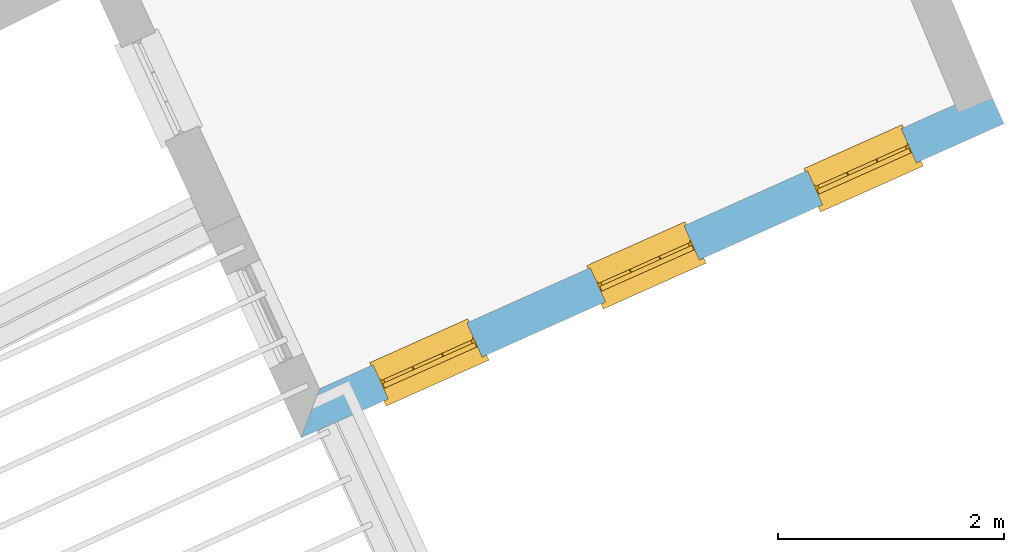
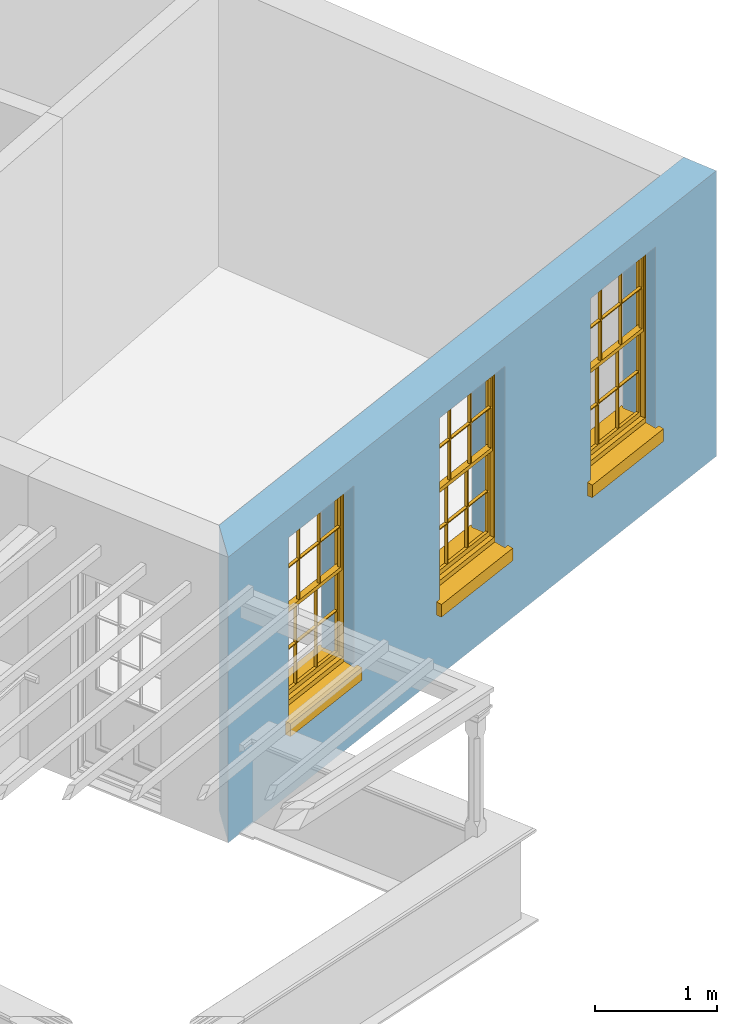
# One storey, part 4 of 9: 3 windows, 3 openings, plus 1 element that does not belong to this part.
"""IFC2X3 building model written with IfcOpenShell, lengths in metres."""

from ifc_helpers import new_model, si_unit, frame, origin, place, context, subcontext, project, spatial, polyline, outline, extrude, faceted_brep, material, layer, layer_set, layer_usage, element, fill, save


model = new_model("IFC2X3")

# Units and contexts
model_context = context("Model", 3, world=origin())
body_context = subcontext(model_context, "Body", "Model", "MODEL_VIEW")
ifc_project = project(units=[si_unit("PLANEANGLEUNIT", "RADIAN"), si_unit("MASSUNIT", "GRAM", prefix="KILO"), si_unit("FORCEUNIT", "NEWTON", prefix="KILO"), si_unit("LENGTHUNIT", "METRE")], contexts=[model_context])

# Site, building, storey
site_placement = place(None, origin())
site = spatial("IfcSite", under=ifc_project, at=site_placement, CompositionType="ELEMENT")
building_placement = place(None, origin())
building = spatial("IfcBuilding", under=site, at=building_placement, Name="Building plot-8", CompositionType="ELEMENT")
storey_placement = place(None, frame((0.0, 0.0, 3.45)))
storey = spatial("IfcBuildingStorey", under=building, at=storey_placement, Name="Floor 1", CompositionType="ELEMENT", Elevation=3.45)

# Wall, openings, windows
ifc_material = material(Name="Masonry")
ifc_layer = layer(ifc_material, 0.33, ventilated=False)
ifc_layer_set = layer_set([ifc_layer], Name="My Wall")
ifc_layer_usage = layer_usage(ifc_layer_set, "AXIS2", "NEGATIVE", 0.08)
wall_placement = place(storey_placement, origin())
wall = element("IfcWallStandardCase", 1, at=wall_placement, inside=storey, material=ifc_layer_usage, Name="exterior", context=body_context, shape_type="SweptSolid", body=[
    extrude(outline(polyline([(25.6887883842839, 9.13469885839309), (25.5254164354395, 8.70019725456561), (31.7366248764663, 11.4767371568641), (31.6019513234471, 11.778006196291), (25.6887883842839, 9.13469885839309)])), origin(), (0.0, 0.0, 1.0), 2.85),
])
opening_1_placement = place(storey_placement, frame((0.0, 0.0, 0.75)))
opening_1 = element("IfcOpeningElement", 2, at=opening_1_placement, cuts=wall, Name="Opening", ObjectType="Opening", context=body_context, shape_type="SweptSolid", body=[
    extrude(outline(polyline([(26.2953527613871, 9.04437487338484), (27.1261249610187, 9.41574739837715), (26.9914514079996, 9.71701643780401), (26.1606792083679, 9.34564391281171), (26.2953527613871, 9.04437487338484)])), origin(), (0.0, 0.0, 1.0), 1.82),
])
opening_2_placement = place(storey_placement, frame((0.0, 0.0, 0.75)))
opening_2 = element("IfcOpeningElement", 3, at=opening_2_placement, cuts=wall, Name="Opening", ObjectType="Opening", context=body_context, shape_type="SweptSolid", body=[
    extrude(outline(polyline([(28.2144135191812, 9.90223511419651), (29.0451857188129, 10.2736076391888), (28.9105121657937, 10.5748766786157), (28.0797399661621, 10.2035041536234), (28.2144135191812, 9.90223511419651)])), origin(), (0.0, 0.0, 1.0), 1.82),
])
opening_3_placement = place(storey_placement, frame((0.0, 0.0, 0.75)))
opening_3 = element("IfcOpeningElement", 4, at=opening_3_placement, cuts=wall, Name="Opening", ObjectType="Opening", context=body_context, shape_type="SweptSolid", body=[
    extrude(outline(polyline([(30.1334742769754, 10.7600953550082), (30.9642464766071, 11.1314678800005), (30.8295729235879, 11.4327369194274), (29.9988007239562, 11.0613643944351), (30.1334742769754, 10.7600953550082)])), origin(), (0.0, 0.0, 1.0), 1.82),
])
window_1_placement = place(storey_placement, frame((26.1933273424331, 9.27260899416277, 0.75), z_axis=(0.0, 0.0, 1.0), x_axis=(0.830772199631671, 0.371372524992305, 0.0)))
window_1 = element("IfcWindow", 5, at=window_1_placement, inside=storey, Name="living outside window", OverallHeight=1.82, OverallWidth=0.91, context=body_context, shape_type="Brep", held_by="IfcProductRepresentation", body=[
    faceted_brep([(0.033125, -0.105, 0.975209), (0.01, -0.105, 0.975209), (0.033125, -0.105, 1.376042), (0.876875, -0.105, 0.975209), (0.876875, -0.105, 1.376042), (0.9, -0.105, 0.975209), (0.876875, -0.105, 1.386042), (0.876875, -0.105, 1.786875), (0.9, -0.105, 1.81), (0.033125, -0.105, 1.786875), (0.033125, -0.105, 1.386042), (0.01, -0.105, 1.81), (0.876875, -0.135, 1.376042), (0.876875, -0.135, 0.975209), (0.9, -0.135, 0.937083), (0.033125, -0.135, 1.786875), (0.01, -0.135, 1.81), (0.033125, -0.135, 1.386042), (0.01, -0.135, 0.937083), (0.033125, -0.135, 0.975209), (0.033125, -0.135, 1.376042), (0.876875, -0.135, 1.786875), (0.876875, -0.135, 1.386042), (0.9, -0.135, 1.81), (0.033125, -0.105, 0.937083), (0.01, -0.105, 0.937083), (0.033125, -0.105, 0.53625), (0.876875, -0.105, 0.937083), (0.876875, -0.105, 0.53625), (0.9, -0.105, 0.937083), (0.876875, -0.105, 0.52625), (0.876875, -0.105, 0.125417), (0.9, -0.105, 0.077167), (0.033125, -0.105, 0.125417), (0.033125, -0.105, 0.52625), (0.01, -0.105, 0.077167), (-0.0425, -0.25, 0.01), (-0.0425, -0.3, 0.001667), (0.0, -0.25, 0.01), (0.9525, -0.25, 0.01), (0.91, -0.25, 0.01), (0.9525, -0.3, 0.001667), (-0.02, 0.08, 0.077167), (0.0, 0.08, 0.077167), (-0.02, 0.11, 0.077167), (0.0, -0.06, 0.077167), (0.01, -0.06, 0.077167), (0.91, -0.06, 0.077167), (0.91, 0.08, 0.077167), (0.9, -0.06, 0.077167), (0.93, 0.08, 0.077167), (0.93, 0.11, 0.077167), (0.01, -0.075, 0.975209), (0.9, -0.075, 0.975209), (0.876875, -0.075, 0.125417), (0.876875, -0.075, 0.52625), (0.9, -0.075, 0.077167), (0.876875, -0.075, 0.53625), (0.876875, -0.075, 0.937083), (0.033125, -0.075, 0.125417), (0.01, -0.075, 0.077167), (0.033125, -0.075, 0.52625), (0.033125, -0.075, 0.937083), (0.033125, -0.075, 0.53625), (-0.02, 0.08, 0.052167), (-0.02, 0.11, 0.052167), (0.93, 0.11, 0.052167), (0.93, 0.08, 0.052167), (0.91, 0.08, 0.052167), (0.0, 0.08, 0.052167), (0.91, -0.15, 0.026667), (0.0, -0.15, 0.026667), (-0.0425, -0.3, -0.123333), (0.9525, -0.3, -0.123333), (-0.0425, -0.25, -0.123333), (0.9525, -0.25, -0.123333), (0.01, -0.06, 1.81), (0.9, -0.06, 1.81), (0.0, -0.06, 1.82), (0.91, -0.06, 1.82), (0.01, -0.15, 0.077167), (0.9, -0.15, 0.077167), (0.592292, -0.105, 0.125417), (0.592292, -0.075, 0.125417), (0.317708, -0.075, 0.125417), (0.317708, -0.105, 0.125417), (0.592292, -0.105, 0.53625), (0.317708, -0.105, 0.53625), (0.317708, -0.105, 0.52625), (0.592292, -0.105, 0.52625), (0.592292, -0.075, 0.53625), (0.317708, -0.075, 0.53625), (0.592292, -0.135, 1.386042), (0.592292, -0.105, 1.386042), (0.317708, -0.105, 1.386042), (0.317708, -0.135, 1.386042), (0.317708, -0.135, 1.376042), (0.592292, -0.135, 1.376042), (0.317708, -0.105, 1.376042), (0.592292, -0.105, 1.376042), (0.602292, -0.135, 1.376042), (0.592292, -0.135, 0.975209), (0.602292, -0.135, 0.975209), (0.602292, -0.105, 0.975209), (0.592292, -0.105, 0.975209), (0.602292, -0.105, 1.376042), (0.602292, -0.075, 0.53625), (0.602292, -0.105, 0.53625), (0.317708, -0.075, 0.52625), (0.307708, -0.075, 0.125417), (0.307708, -0.075, 0.52625), (0.602292, -0.075, 0.52625), (0.602292, -0.075, 0.125417), (0.592292, -0.075, 0.52625), (0.307708, -0.075, 0.53625), (0.317708, -0.075, 0.937083), (0.307708, -0.075, 0.937083), (0.602292, -0.075, 0.937083), (0.592292, -0.075, 0.937083), (0.307708, -0.105, 0.52625), (0.307708, -0.105, 0.125417), (0.307708, -0.105, 0.53625), (0.307708, -0.105, 0.937083), (0.592292, -0.105, 0.937083), (0.317708, -0.105, 0.937083), (0.602292, -0.105, 0.937083), (0.602292, -0.105, 0.52625), (0.602292, -0.105, 0.125417), (0.307708, -0.135, 1.386042), (0.307708, -0.135, 1.376042), (0.307708, -0.135, 0.975209), (0.317708, -0.135, 0.975209), (0.317708, -0.135, 1.786875), (0.307708, -0.135, 1.786875), (0.602292, -0.135, 1.786875), (0.592292, -0.135, 1.786875), (0.602292, -0.135, 1.386042), (0.602292, -0.105, 1.386042), (0.307708, -0.105, 1.386042), (0.307708, -0.105, 1.786875), (0.317708, -0.105, 1.786875), (0.592292, -0.105, 1.786875), (0.602292, -0.105, 1.786875), (0.307708, -0.105, 1.376042), (0.317708, -0.105, 0.975209), (0.307708, -0.105, 0.975209), (0.91, -0.15, 1.82), (0.9, -0.15, 1.81), (0.01, -0.15, 1.81), (0.0, -0.15, 1.82), (0.91, -0.25, 0.0), (0.0, -0.25, 0.0), (0.91, 0.08, 0.0), (0.0, 0.08, 0.0)], [[[0, 1, 2]], [[3, 4, 5]], [[6, 7, 8]], [[9, 10, 11]], [[12, 13, 14]], [[15, 16, 17]], [[18, 19, 20]], [[21, 22, 23]], [[24, 25, 26]], [[27, 28, 29]], [[30, 31, 32]], [[33, 34, 35]], [[14, 27, 29]], [[25, 24, 18]], [[36, 37, 38]], [[39, 40, 41]], [[42, 43, 44]], [[45, 46, 43]], [[47, 48, 49]], [[50, 51, 48]], [[1, 0, 52]], [[5, 53, 3]], [[54, 55, 56]], [[57, 58, 53]], [[59, 60, 61]], [[62, 63, 52]], [[48, 43, 46, 49]], [[51, 44, 43, 48]], [[64, 42, 44, 65]], [[65, 44, 51, 66]], [[66, 51, 50, 67]], [[65, 66, 68, 69]], [[60, 56, 49, 46]], [[70, 71, 38, 40]], [[37, 41, 40, 38]], [[37, 72, 73, 41]], [[74, 75, 73, 72]], [[8, 11, 76, 77]], [[76, 78, 79, 77]], [[32, 35, 80, 81]], [[81, 80, 71, 70]], [[82, 83, 84, 85]], [[86, 87, 88, 89]], [[86, 90, 91, 87]], [[92, 93, 94, 95]], [[92, 95, 96, 97]], [[96, 98, 99, 97]], [[100, 97, 101, 102]], [[103, 104, 99, 105]], [[97, 99, 104, 101]], [[102, 103, 105, 100]], [[28, 57, 106, 107]], [[108, 84, 109, 110]], [[111, 112, 83, 113]], [[114, 110, 61, 63]], [[90, 113, 108, 91]], [[115, 91, 114, 116]], [[117, 106, 90, 118]], [[111, 106, 57, 55]], [[119, 110, 109, 120]], [[34, 61, 110, 119]], [[89, 113, 83, 82]], [[88, 108, 113, 89]], [[85, 84, 108, 88]], [[121, 114, 63, 26]], [[122, 116, 114, 121]], [[123, 118, 90, 86]], [[87, 91, 115, 124]], [[107, 106, 117, 125]], [[126, 111, 55, 30]], [[127, 112, 111, 126]], [[126, 30, 28, 107]], [[88, 119, 120, 85]], [[126, 89, 82, 127]], [[125, 123, 86, 107]], [[121, 26, 34, 119]], [[124, 122, 121, 87]], [[128, 17, 20, 129]], [[96, 129, 130, 131]], [[132, 133, 128, 95]], [[134, 135, 92, 136]], [[100, 12, 22, 136]], [[137, 6, 4, 105]], [[94, 138, 139, 140]], [[137, 93, 141, 142]], [[99, 98, 94, 93]], [[143, 2, 10, 138]], [[144, 145, 143, 98]], [[129, 143, 145, 130]], [[20, 2, 143, 129]], [[131, 144, 98, 96]], [[128, 138, 10, 17]], [[133, 139, 138, 128]], [[135, 141, 93, 92]], [[95, 94, 140, 132]], [[22, 6, 137, 136]], [[136, 137, 142, 134]], [[100, 105, 4, 12]], [[107, 86, 89, 126]], [[106, 111, 113, 90]], [[91, 108, 110, 114]], [[87, 121, 119, 88]], [[97, 100, 136, 92]], [[129, 96, 95, 128]], [[98, 143, 138, 94]], [[105, 99, 93, 137]], [[131, 101, 104, 144]], [[124, 115, 118, 123]], [[132, 140, 141, 135]], [[120, 109, 59, 33]], [[15, 9, 139, 133]], [[134, 142, 7, 21]], [[31, 54, 112, 127]], [[36, 74, 72, 37]], [[39, 41, 73, 75]], [[18, 14, 101, 131]], [[23, 16, 132, 135]], [[83, 56, 60, 84]], [[52, 53, 118, 115]], [[53, 52, 144, 104]], [[11, 8, 141, 140]], [[14, 18, 124, 123]], [[2, 1, 11, 10]], [[8, 5, 4, 6]], [[57, 53, 56, 55]], [[60, 52, 63, 61]], [[26, 25, 35, 34]], [[32, 29, 28, 30]], [[14, 23, 22, 12]], [[18, 20, 17, 16]], [[19, 0, 2, 20]], [[17, 10, 9, 15]], [[12, 4, 3, 13]], [[21, 7, 6, 22]], [[27, 58, 57, 28]], [[30, 55, 54, 31]], [[33, 59, 61, 34]], [[26, 63, 62, 24]], [[5, 8, 77, 53]], [[76, 11, 1, 52]], [[46, 45, 78, 76]], [[49, 77, 79, 47]], [[70, 146, 147, 81]], [[71, 80, 148, 149]], [[19, 130, 145, 0]], [[102, 13, 3, 103]], [[116, 122, 24, 62]], [[29, 32, 81, 14]], [[80, 35, 25, 18]], [[60, 46, 76, 52]], [[77, 49, 56, 53]], [[23, 14, 81, 147]], [[16, 148, 80, 18]], [[35, 85, 120]], [[120, 33, 35]], [[127, 82, 32]], [[32, 31, 127]], [[32, 82, 85, 35]], [[102, 101, 14]], [[14, 13, 102]], [[18, 131, 130]], [[130, 19, 18]], [[134, 21, 23]], [[23, 135, 134]], [[16, 15, 133]], [[133, 132, 16]], [[11, 140, 139]], [[139, 9, 11]], [[142, 141, 8]], [[8, 7, 142]], [[23, 147, 148, 16]], [[146, 149, 148, 147]], [[52, 115, 116]], [[116, 62, 52]], [[118, 53, 117]], [[58, 117, 53]], [[27, 125, 117, 58]], [[56, 83, 112]], [[112, 54, 56]], [[109, 84, 60]], [[60, 59, 109]], [[125, 27, 14]], [[14, 123, 125]], [[122, 124, 18]], [[18, 24, 122]], [[145, 144, 52]], [[52, 0, 145]], [[103, 3, 53]], [[53, 104, 103]], [[79, 78, 149, 146]], [[78, 45, 71, 149]], [[146, 70, 47, 79]], [[150, 75, 74, 151]], [[68, 66, 67]], [[48, 68, 67, 50]], [[69, 64, 65]], [[42, 64, 69, 43]], [[69, 68, 152, 153]], [[70, 68, 48, 47]], [[150, 152, 68, 70]], [[43, 69, 71, 45]], [[69, 153, 151, 71]], [[152, 150, 151, 153]], [[38, 151, 74, 36]], [[71, 151, 38]], [[39, 75, 150, 40]], [[40, 150, 70]]]),
])
fill(opening_1, window_1)
window_2_placement = place(storey_placement, frame((28.1123881002273, 10.1304692349744, 0.75), z_axis=(0.0, 0.0, 1.0), x_axis=(0.830772199631671, 0.371372524992303, 0.0)))
window_2 = element("IfcWindow", 6, at=window_2_placement, inside=storey, Name="living outside window", OverallHeight=1.82, OverallWidth=0.91, context=body_context, shape_type="Brep", held_by="IfcProductRepresentation", body=[
    faceted_brep([(0.033125, -0.105, 0.975209), (0.01, -0.105, 0.975209), (0.033125, -0.105, 1.376042), (0.876875, -0.105, 0.975209), (0.876875, -0.105, 1.376042), (0.9, -0.105, 0.975209), (0.876875, -0.105, 1.386042), (0.876875, -0.105, 1.786875), (0.9, -0.105, 1.81), (0.033125, -0.105, 1.786875), (0.033125, -0.105, 1.386042), (0.01, -0.105, 1.81), (0.876875, -0.135, 1.376042), (0.876875, -0.135, 0.975209), (0.9, -0.135, 0.937083), (0.033125, -0.135, 1.786875), (0.01, -0.135, 1.81), (0.033125, -0.135, 1.386042), (0.01, -0.135, 0.937083), (0.033125, -0.135, 0.975209), (0.033125, -0.135, 1.376042), (0.876875, -0.135, 1.786875), (0.876875, -0.135, 1.386042), (0.9, -0.135, 1.81), (0.033125, -0.105, 0.937083), (0.01, -0.105, 0.937083), (0.033125, -0.105, 0.53625), (0.876875, -0.105, 0.937083), (0.876875, -0.105, 0.53625), (0.9, -0.105, 0.937083), (0.876875, -0.105, 0.52625), (0.876875, -0.105, 0.125417), (0.9, -0.105, 0.077167), (0.033125, -0.105, 0.125417), (0.033125, -0.105, 0.52625), (0.01, -0.105, 0.077167), (-0.0425, -0.25, 0.01), (-0.0425, -0.3, 0.001667), (0.0, -0.25, 0.01), (0.9525, -0.25, 0.01), (0.91, -0.25, 0.01), (0.9525, -0.3, 0.001667), (-0.02, 0.08, 0.077167), (0.0, 0.08, 0.077167), (-0.02, 0.11, 0.077167), (0.0, -0.06, 0.077167), (0.01, -0.06, 0.077167), (0.91, -0.06, 0.077167), (0.91, 0.08, 0.077167), (0.9, -0.06, 0.077167), (0.93, 0.08, 0.077167), (0.93, 0.11, 0.077167), (0.01, -0.075, 0.975209), (0.9, -0.075, 0.975209), (0.876875, -0.075, 0.125417), (0.876875, -0.075, 0.52625), (0.9, -0.075, 0.077167), (0.876875, -0.075, 0.53625), (0.876875, -0.075, 0.937083), (0.033125, -0.075, 0.125417), (0.01, -0.075, 0.077167), (0.033125, -0.075, 0.52625), (0.033125, -0.075, 0.937083), (0.033125, -0.075, 0.53625), (-0.02, 0.08, 0.052167), (-0.02, 0.11, 0.052167), (0.93, 0.11, 0.052167), (0.93, 0.08, 0.052167), (0.91, 0.08, 0.052167), (0.0, 0.08, 0.052167), (0.91, -0.15, 0.026667), (0.0, -0.15, 0.026667), (-0.0425, -0.3, -0.123333), (0.9525, -0.3, -0.123333), (-0.0425, -0.25, -0.123333), (0.9525, -0.25, -0.123333), (0.01, -0.06, 1.81), (0.9, -0.06, 1.81), (0.0, -0.06, 1.82), (0.91, -0.06, 1.82), (0.01, -0.15, 0.077167), (0.9, -0.15, 0.077167), (0.592292, -0.105, 0.125417), (0.592292, -0.075, 0.125417), (0.317708, -0.075, 0.125417), (0.317708, -0.105, 0.125417), (0.592292, -0.105, 0.53625), (0.317708, -0.105, 0.53625), (0.317708, -0.105, 0.52625), (0.592292, -0.105, 0.52625), (0.592292, -0.075, 0.53625), (0.317708, -0.075, 0.53625), (0.592292, -0.135, 1.386042), (0.592292, -0.105, 1.386042), (0.317708, -0.105, 1.386042), (0.317708, -0.135, 1.386042), (0.317708, -0.135, 1.376042), (0.592292, -0.135, 1.376042), (0.317708, -0.105, 1.376042), (0.592292, -0.105, 1.376042), (0.602292, -0.135, 1.376042), (0.592292, -0.135, 0.975209), (0.602292, -0.135, 0.975209), (0.602292, -0.105, 0.975209), (0.592292, -0.105, 0.975209), (0.602292, -0.105, 1.376042), (0.602292, -0.075, 0.53625), (0.602292, -0.105, 0.53625), (0.317708, -0.075, 0.52625), (0.307708, -0.075, 0.125417), (0.307708, -0.075, 0.52625), (0.602292, -0.075, 0.52625), (0.602292, -0.075, 0.125417), (0.592292, -0.075, 0.52625), (0.307708, -0.075, 0.53625), (0.317708, -0.075, 0.937083), (0.307708, -0.075, 0.937083), (0.602292, -0.075, 0.937083), (0.592292, -0.075, 0.937083), (0.307708, -0.105, 0.52625), (0.307708, -0.105, 0.125417), (0.307708, -0.105, 0.53625), (0.307708, -0.105, 0.937083), (0.592292, -0.105, 0.937083), (0.317708, -0.105, 0.937083), (0.602292, -0.105, 0.937083), (0.602292, -0.105, 0.52625), (0.602292, -0.105, 0.125417), (0.307708, -0.135, 1.386042), (0.307708, -0.135, 1.376042), (0.307708, -0.135, 0.975209), (0.317708, -0.135, 0.975209), (0.317708, -0.135, 1.786875), (0.307708, -0.135, 1.786875), (0.602292, -0.135, 1.786875), (0.592292, -0.135, 1.786875), (0.602292, -0.135, 1.386042), (0.602292, -0.105, 1.386042), (0.307708, -0.105, 1.386042), (0.307708, -0.105, 1.786875), (0.317708, -0.105, 1.786875), (0.592292, -0.105, 1.786875), (0.602292, -0.105, 1.786875), (0.307708, -0.105, 1.376042), (0.317708, -0.105, 0.975209), (0.307708, -0.105, 0.975209), (0.91, -0.15, 1.82), (0.9, -0.15, 1.81), (0.01, -0.15, 1.81), (0.0, -0.15, 1.82), (0.91, -0.25, 0.0), (0.0, -0.25, 0.0), (0.91, 0.08, 0.0), (0.0, 0.08, 0.0)], [[[0, 1, 2]], [[3, 4, 5]], [[6, 7, 8]], [[9, 10, 11]], [[12, 13, 14]], [[15, 16, 17]], [[18, 19, 20]], [[21, 22, 23]], [[24, 25, 26]], [[27, 28, 29]], [[30, 31, 32]], [[33, 34, 35]], [[14, 27, 29]], [[25, 24, 18]], [[36, 37, 38]], [[39, 40, 41]], [[42, 43, 44]], [[45, 46, 43]], [[47, 48, 49]], [[50, 51, 48]], [[1, 0, 52]], [[5, 53, 3]], [[54, 55, 56]], [[57, 58, 53]], [[59, 60, 61]], [[62, 63, 52]], [[48, 43, 46, 49]], [[51, 44, 43, 48]], [[64, 42, 44, 65]], [[65, 44, 51, 66]], [[66, 51, 50, 67]], [[65, 66, 68, 69]], [[60, 56, 49, 46]], [[70, 71, 38, 40]], [[37, 41, 40, 38]], [[37, 72, 73, 41]], [[74, 75, 73, 72]], [[8, 11, 76, 77]], [[76, 78, 79, 77]], [[32, 35, 80, 81]], [[81, 80, 71, 70]], [[82, 83, 84, 85]], [[86, 87, 88, 89]], [[86, 90, 91, 87]], [[92, 93, 94, 95]], [[92, 95, 96, 97]], [[96, 98, 99, 97]], [[100, 97, 101, 102]], [[103, 104, 99, 105]], [[97, 99, 104, 101]], [[102, 103, 105, 100]], [[28, 57, 106, 107]], [[108, 84, 109, 110]], [[111, 112, 83, 113]], [[114, 110, 61, 63]], [[90, 113, 108, 91]], [[115, 91, 114, 116]], [[117, 106, 90, 118]], [[111, 106, 57, 55]], [[119, 110, 109, 120]], [[34, 61, 110, 119]], [[89, 113, 83, 82]], [[88, 108, 113, 89]], [[85, 84, 108, 88]], [[121, 114, 63, 26]], [[122, 116, 114, 121]], [[123, 118, 90, 86]], [[87, 91, 115, 124]], [[107, 106, 117, 125]], [[126, 111, 55, 30]], [[127, 112, 111, 126]], [[126, 30, 28, 107]], [[88, 119, 120, 85]], [[126, 89, 82, 127]], [[125, 123, 86, 107]], [[121, 26, 34, 119]], [[124, 122, 121, 87]], [[128, 17, 20, 129]], [[96, 129, 130, 131]], [[132, 133, 128, 95]], [[134, 135, 92, 136]], [[100, 12, 22, 136]], [[137, 6, 4, 105]], [[94, 138, 139, 140]], [[137, 93, 141, 142]], [[99, 98, 94, 93]], [[143, 2, 10, 138]], [[144, 145, 143, 98]], [[129, 143, 145, 130]], [[20, 2, 143, 129]], [[131, 144, 98, 96]], [[128, 138, 10, 17]], [[133, 139, 138, 128]], [[135, 141, 93, 92]], [[95, 94, 140, 132]], [[22, 6, 137, 136]], [[136, 137, 142, 134]], [[100, 105, 4, 12]], [[107, 86, 89, 126]], [[106, 111, 113, 90]], [[91, 108, 110, 114]], [[87, 121, 119, 88]], [[97, 100, 136, 92]], [[129, 96, 95, 128]], [[98, 143, 138, 94]], [[105, 99, 93, 137]], [[131, 101, 104, 144]], [[124, 115, 118, 123]], [[132, 140, 141, 135]], [[120, 109, 59, 33]], [[15, 9, 139, 133]], [[134, 142, 7, 21]], [[31, 54, 112, 127]], [[36, 74, 72, 37]], [[39, 41, 73, 75]], [[18, 14, 101, 131]], [[23, 16, 132, 135]], [[83, 56, 60, 84]], [[52, 53, 118, 115]], [[53, 52, 144, 104]], [[11, 8, 141, 140]], [[14, 18, 124, 123]], [[2, 1, 11, 10]], [[8, 5, 4, 6]], [[57, 53, 56, 55]], [[60, 52, 63, 61]], [[26, 25, 35, 34]], [[32, 29, 28, 30]], [[14, 23, 22, 12]], [[18, 20, 17, 16]], [[19, 0, 2, 20]], [[17, 10, 9, 15]], [[12, 4, 3, 13]], [[21, 7, 6, 22]], [[27, 58, 57, 28]], [[30, 55, 54, 31]], [[33, 59, 61, 34]], [[26, 63, 62, 24]], [[5, 8, 77, 53]], [[76, 11, 1, 52]], [[46, 45, 78, 76]], [[49, 77, 79, 47]], [[70, 146, 147, 81]], [[71, 80, 148, 149]], [[19, 130, 145, 0]], [[102, 13, 3, 103]], [[116, 122, 24, 62]], [[29, 32, 81, 14]], [[80, 35, 25, 18]], [[60, 46, 76, 52]], [[77, 49, 56, 53]], [[23, 14, 81, 147]], [[16, 148, 80, 18]], [[35, 85, 120]], [[120, 33, 35]], [[127, 82, 32]], [[32, 31, 127]], [[32, 82, 85, 35]], [[102, 101, 14]], [[14, 13, 102]], [[18, 131, 130]], [[130, 19, 18]], [[134, 21, 23]], [[23, 135, 134]], [[16, 15, 133]], [[133, 132, 16]], [[11, 140, 139]], [[139, 9, 11]], [[142, 141, 8]], [[8, 7, 142]], [[23, 147, 148, 16]], [[146, 149, 148, 147]], [[52, 115, 116]], [[116, 62, 52]], [[118, 53, 117]], [[58, 117, 53]], [[27, 125, 117, 58]], [[56, 83, 112]], [[112, 54, 56]], [[109, 84, 60]], [[60, 59, 109]], [[125, 27, 14]], [[14, 123, 125]], [[122, 124, 18]], [[18, 24, 122]], [[145, 144, 52]], [[52, 0, 145]], [[103, 3, 53]], [[53, 104, 103]], [[79, 78, 149, 146]], [[78, 45, 71, 149]], [[146, 70, 47, 79]], [[150, 75, 74, 151]], [[68, 66, 67]], [[48, 68, 67, 50]], [[69, 64, 65]], [[42, 64, 69, 43]], [[69, 68, 152, 153]], [[70, 68, 48, 47]], [[150, 152, 68, 70]], [[43, 69, 71, 45]], [[69, 153, 151, 71]], [[152, 150, 151, 153]], [[38, 151, 74, 36]], [[71, 151, 38]], [[39, 75, 150, 40]], [[40, 150, 70]]]),
])
fill(opening_2, window_2)
window_3_placement = place(storey_placement, frame((30.0314488580215, 10.9883294757861, 0.75), z_axis=(0.0, 0.0, 1.0), x_axis=(0.830772199631671, 0.371372524992303, 0.0)))
window_3 = element("IfcWindow", 7, at=window_3_placement, inside=storey, Name="living outside window", OverallHeight=1.82, OverallWidth=0.91, context=body_context, shape_type="Brep", held_by="IfcProductRepresentation", body=[
    faceted_brep([(0.033125, -0.105, 0.975209), (0.01, -0.105, 0.975209), (0.033125, -0.105, 1.376042), (0.876875, -0.105, 0.975209), (0.876875, -0.105, 1.376042), (0.9, -0.105, 0.975209), (0.876875, -0.105, 1.386042), (0.876875, -0.105, 1.786875), (0.9, -0.105, 1.81), (0.033125, -0.105, 1.786875), (0.033125, -0.105, 1.386042), (0.01, -0.105, 1.81), (0.876875, -0.135, 1.376042), (0.876875, -0.135, 0.975209), (0.9, -0.135, 0.937083), (0.033125, -0.135, 1.786875), (0.01, -0.135, 1.81), (0.033125, -0.135, 1.386042), (0.01, -0.135, 0.937083), (0.033125, -0.135, 0.975209), (0.033125, -0.135, 1.376042), (0.876875, -0.135, 1.786875), (0.876875, -0.135, 1.386042), (0.9, -0.135, 1.81), (0.033125, -0.105, 0.937083), (0.01, -0.105, 0.937083), (0.033125, -0.105, 0.53625), (0.876875, -0.105, 0.937083), (0.876875, -0.105, 0.53625), (0.9, -0.105, 0.937083), (0.876875, -0.105, 0.52625), (0.876875, -0.105, 0.125417), (0.9, -0.105, 0.077167), (0.033125, -0.105, 0.125417), (0.033125, -0.105, 0.52625), (0.01, -0.105, 0.077167), (-0.0425, -0.25, 0.01), (-0.0425, -0.3, 0.001667), (0.0, -0.25, 0.01), (0.9525, -0.25, 0.01), (0.91, -0.25, 0.01), (0.9525, -0.3, 0.001667), (-0.02, 0.08, 0.077167), (0.0, 0.08, 0.077167), (-0.02, 0.11, 0.077167), (0.0, -0.06, 0.077167), (0.01, -0.06, 0.077167), (0.91, -0.06, 0.077167), (0.91, 0.08, 0.077167), (0.9, -0.06, 0.077167), (0.93, 0.08, 0.077167), (0.93, 0.11, 0.077167), (0.01, -0.075, 0.975209), (0.9, -0.075, 0.975209), (0.876875, -0.075, 0.125417), (0.876875, -0.075, 0.52625), (0.9, -0.075, 0.077167), (0.876875, -0.075, 0.53625), (0.876875, -0.075, 0.937083), (0.033125, -0.075, 0.125417), (0.01, -0.075, 0.077167), (0.033125, -0.075, 0.52625), (0.033125, -0.075, 0.937083), (0.033125, -0.075, 0.53625), (-0.02, 0.08, 0.052167), (-0.02, 0.11, 0.052167), (0.93, 0.11, 0.052167), (0.93, 0.08, 0.052167), (0.91, 0.08, 0.052167), (0.0, 0.08, 0.052167), (0.91, -0.15, 0.026667), (0.0, -0.15, 0.026667), (-0.0425, -0.3, -0.123333), (0.9525, -0.3, -0.123333), (-0.0425, -0.25, -0.123333), (0.9525, -0.25, -0.123333), (0.01, -0.06, 1.81), (0.9, -0.06, 1.81), (0.0, -0.06, 1.82), (0.91, -0.06, 1.82), (0.01, -0.15, 0.077167), (0.9, -0.15, 0.077167), (0.592292, -0.105, 0.125417), (0.592292, -0.075, 0.125417), (0.317708, -0.075, 0.125417), (0.317708, -0.105, 0.125417), (0.592292, -0.105, 0.53625), (0.317708, -0.105, 0.53625), (0.317708, -0.105, 0.52625), (0.592292, -0.105, 0.52625), (0.592292, -0.075, 0.53625), (0.317708, -0.075, 0.53625), (0.592292, -0.135, 1.386042), (0.592292, -0.105, 1.386042), (0.317708, -0.105, 1.386042), (0.317708, -0.135, 1.386042), (0.317708, -0.135, 1.376042), (0.592292, -0.135, 1.376042), (0.317708, -0.105, 1.376042), (0.592292, -0.105, 1.376042), (0.602292, -0.135, 1.376042), (0.592292, -0.135, 0.975209), (0.602292, -0.135, 0.975209), (0.602292, -0.105, 0.975209), (0.592292, -0.105, 0.975209), (0.602292, -0.105, 1.376042), (0.602292, -0.075, 0.53625), (0.602292, -0.105, 0.53625), (0.317708, -0.075, 0.52625), (0.307708, -0.075, 0.125417), (0.307708, -0.075, 0.52625), (0.602292, -0.075, 0.52625), (0.602292, -0.075, 0.125417), (0.592292, -0.075, 0.52625), (0.307708, -0.075, 0.53625), (0.317708, -0.075, 0.937083), (0.307708, -0.075, 0.937083), (0.602292, -0.075, 0.937083), (0.592292, -0.075, 0.937083), (0.307708, -0.105, 0.52625), (0.307708, -0.105, 0.125417), (0.307708, -0.105, 0.53625), (0.307708, -0.105, 0.937083), (0.592292, -0.105, 0.937083), (0.317708, -0.105, 0.937083), (0.602292, -0.105, 0.937083), (0.602292, -0.105, 0.52625), (0.602292, -0.105, 0.125417), (0.307708, -0.135, 1.386042), (0.307708, -0.135, 1.376042), (0.307708, -0.135, 0.975209), (0.317708, -0.135, 0.975209), (0.317708, -0.135, 1.786875), (0.307708, -0.135, 1.786875), (0.602292, -0.135, 1.786875), (0.592292, -0.135, 1.786875), (0.602292, -0.135, 1.386042), (0.602292, -0.105, 1.386042), (0.307708, -0.105, 1.386042), (0.307708, -0.105, 1.786875), (0.317708, -0.105, 1.786875), (0.592292, -0.105, 1.786875), (0.602292, -0.105, 1.786875), (0.307708, -0.105, 1.376042), (0.317708, -0.105, 0.975209), (0.307708, -0.105, 0.975209), (0.91, -0.15, 1.82), (0.9, -0.15, 1.81), (0.01, -0.15, 1.81), (0.0, -0.15, 1.82), (0.91, -0.25, 0.0), (0.0, -0.25, 0.0), (0.91, 0.08, 0.0), (0.0, 0.08, 0.0)], [[[0, 1, 2]], [[3, 4, 5]], [[6, 7, 8]], [[9, 10, 11]], [[12, 13, 14]], [[15, 16, 17]], [[18, 19, 20]], [[21, 22, 23]], [[24, 25, 26]], [[27, 28, 29]], [[30, 31, 32]], [[33, 34, 35]], [[14, 27, 29]], [[25, 24, 18]], [[36, 37, 38]], [[39, 40, 41]], [[42, 43, 44]], [[45, 46, 43]], [[47, 48, 49]], [[50, 51, 48]], [[1, 0, 52]], [[5, 53, 3]], [[54, 55, 56]], [[57, 58, 53]], [[59, 60, 61]], [[62, 63, 52]], [[48, 43, 46, 49]], [[51, 44, 43, 48]], [[64, 42, 44, 65]], [[65, 44, 51, 66]], [[66, 51, 50, 67]], [[65, 66, 68, 69]], [[60, 56, 49, 46]], [[70, 71, 38, 40]], [[37, 41, 40, 38]], [[37, 72, 73, 41]], [[74, 75, 73, 72]], [[8, 11, 76, 77]], [[76, 78, 79, 77]], [[32, 35, 80, 81]], [[81, 80, 71, 70]], [[82, 83, 84, 85]], [[86, 87, 88, 89]], [[86, 90, 91, 87]], [[92, 93, 94, 95]], [[92, 95, 96, 97]], [[96, 98, 99, 97]], [[100, 97, 101, 102]], [[103, 104, 99, 105]], [[97, 99, 104, 101]], [[102, 103, 105, 100]], [[28, 57, 106, 107]], [[108, 84, 109, 110]], [[111, 112, 83, 113]], [[114, 110, 61, 63]], [[90, 113, 108, 91]], [[115, 91, 114, 116]], [[117, 106, 90, 118]], [[111, 106, 57, 55]], [[119, 110, 109, 120]], [[34, 61, 110, 119]], [[89, 113, 83, 82]], [[88, 108, 113, 89]], [[85, 84, 108, 88]], [[121, 114, 63, 26]], [[122, 116, 114, 121]], [[123, 118, 90, 86]], [[87, 91, 115, 124]], [[107, 106, 117, 125]], [[126, 111, 55, 30]], [[127, 112, 111, 126]], [[126, 30, 28, 107]], [[88, 119, 120, 85]], [[126, 89, 82, 127]], [[125, 123, 86, 107]], [[121, 26, 34, 119]], [[124, 122, 121, 87]], [[128, 17, 20, 129]], [[96, 129, 130, 131]], [[132, 133, 128, 95]], [[134, 135, 92, 136]], [[100, 12, 22, 136]], [[137, 6, 4, 105]], [[94, 138, 139, 140]], [[137, 93, 141, 142]], [[99, 98, 94, 93]], [[143, 2, 10, 138]], [[144, 145, 143, 98]], [[129, 143, 145, 130]], [[20, 2, 143, 129]], [[131, 144, 98, 96]], [[128, 138, 10, 17]], [[133, 139, 138, 128]], [[135, 141, 93, 92]], [[95, 94, 140, 132]], [[22, 6, 137, 136]], [[136, 137, 142, 134]], [[100, 105, 4, 12]], [[107, 86, 89, 126]], [[106, 111, 113, 90]], [[91, 108, 110, 114]], [[87, 121, 119, 88]], [[97, 100, 136, 92]], [[129, 96, 95, 128]], [[98, 143, 138, 94]], [[105, 99, 93, 137]], [[131, 101, 104, 144]], [[124, 115, 118, 123]], [[132, 140, 141, 135]], [[120, 109, 59, 33]], [[15, 9, 139, 133]], [[134, 142, 7, 21]], [[31, 54, 112, 127]], [[36, 74, 72, 37]], [[39, 41, 73, 75]], [[18, 14, 101, 131]], [[23, 16, 132, 135]], [[83, 56, 60, 84]], [[52, 53, 118, 115]], [[53, 52, 144, 104]], [[11, 8, 141, 140]], [[14, 18, 124, 123]], [[2, 1, 11, 10]], [[8, 5, 4, 6]], [[57, 53, 56, 55]], [[60, 52, 63, 61]], [[26, 25, 35, 34]], [[32, 29, 28, 30]], [[14, 23, 22, 12]], [[18, 20, 17, 16]], [[19, 0, 2, 20]], [[17, 10, 9, 15]], [[12, 4, 3, 13]], [[21, 7, 6, 22]], [[27, 58, 57, 28]], [[30, 55, 54, 31]], [[33, 59, 61, 34]], [[26, 63, 62, 24]], [[5, 8, 77, 53]], [[76, 11, 1, 52]], [[46, 45, 78, 76]], [[49, 77, 79, 47]], [[70, 146, 147, 81]], [[71, 80, 148, 149]], [[19, 130, 145, 0]], [[102, 13, 3, 103]], [[116, 122, 24, 62]], [[29, 32, 81, 14]], [[80, 35, 25, 18]], [[60, 46, 76, 52]], [[77, 49, 56, 53]], [[23, 14, 81, 147]], [[16, 148, 80, 18]], [[35, 85, 120]], [[120, 33, 35]], [[127, 82, 32]], [[32, 31, 127]], [[32, 82, 85, 35]], [[102, 101, 14]], [[14, 13, 102]], [[18, 131, 130]], [[130, 19, 18]], [[134, 21, 23]], [[23, 135, 134]], [[16, 15, 133]], [[133, 132, 16]], [[11, 140, 139]], [[139, 9, 11]], [[142, 141, 8]], [[8, 7, 142]], [[23, 147, 148, 16]], [[146, 149, 148, 147]], [[52, 115, 116]], [[116, 62, 52]], [[118, 53, 117]], [[58, 117, 53]], [[27, 125, 117, 58]], [[56, 83, 112]], [[112, 54, 56]], [[109, 84, 60]], [[60, 59, 109]], [[125, 27, 14]], [[14, 123, 125]], [[122, 124, 18]], [[18, 24, 122]], [[145, 144, 52]], [[52, 0, 145]], [[103, 3, 53]], [[53, 104, 103]], [[79, 78, 149, 146]], [[78, 45, 71, 149]], [[146, 70, 47, 79]], [[150, 75, 74, 151]], [[68, 66, 67]], [[48, 68, 67, 50]], [[69, 64, 65]], [[42, 64, 69, 43]], [[69, 68, 152, 153]], [[70, 68, 48, 47]], [[150, 152, 68, 70]], [[43, 69, 71, 45]], [[69, 153, 151, 71]], [[152, 150, 151, 153]], [[38, 151, 74, 36]], [[71, 151, 38]], [[39, 75, 150, 40]], [[40, 150, 70]]]),
])
fill(opening_3, window_3)

save(model, "model.ifc")
